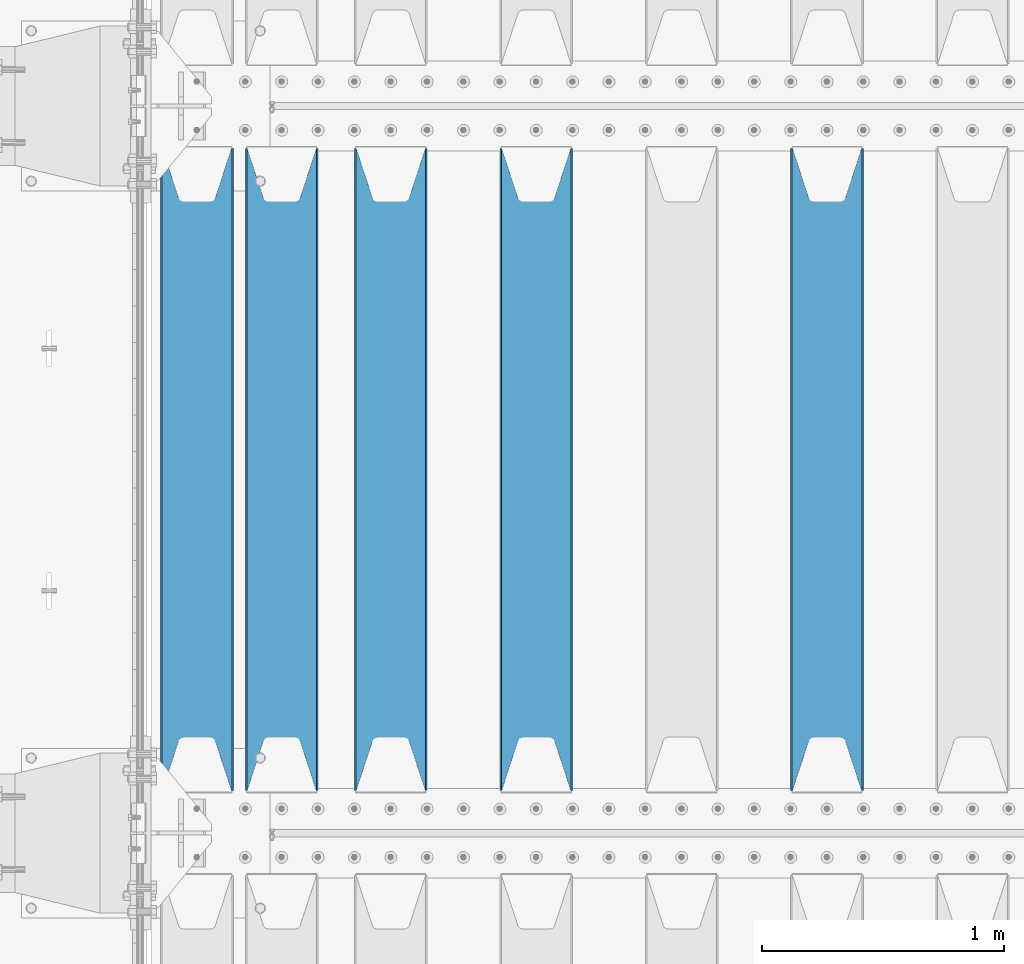
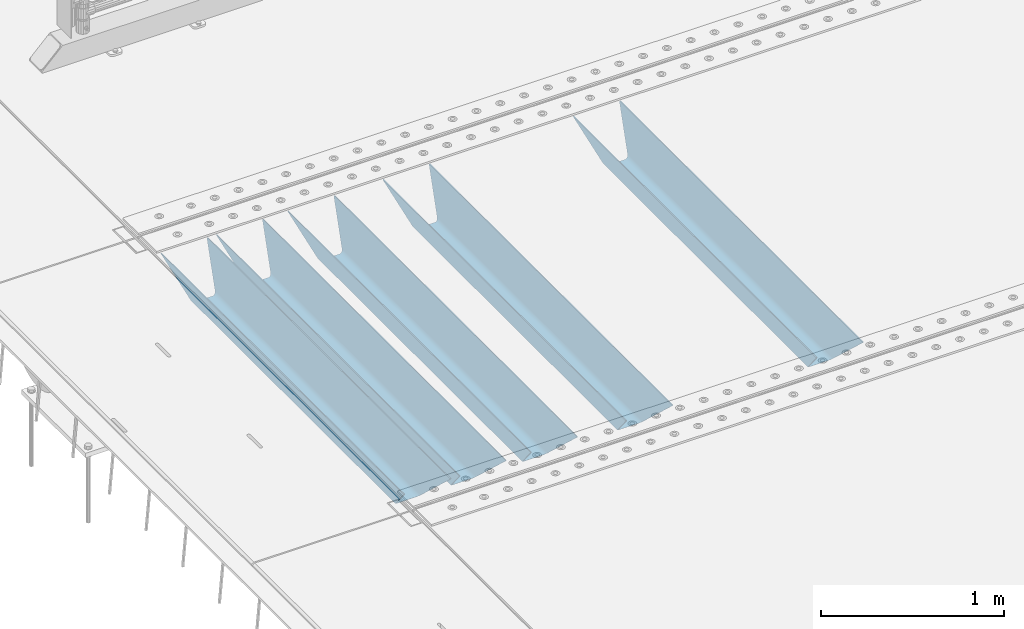
# One storey, part 110 of 247: 5 beams.
"""IFC2X3 building model written with IfcOpenShell, lengths in millimetres."""

import ifcopenshell
import ifcopenshell.guid

model = None  # the IFC model being written
_history = None  # IfcOwnerHistory: only IFC2X3 demands one
_inside = {}  # id of a spatial element -> (the spatial element, [elements in it])
_under = {}  # id of a project, library or spatial element -> (it, [spatial elements below it])
_declared = {}  # id of a project -> (the project, [libraries it declares])
_typed = {}  # id of a type object -> (the type object, [elements of that type])
_made_of = {}  # id of a material, layer set ... -> (it, [elements and type objects made of it])


def new_model(schema):
    """Start an empty IFC model of exactly this schema.

    Asked for "IFC4X3", IfcOpenShell would pick the latest addendum, in which some entities
    have other attributes; the version numbers below select the first issue.
    IFC2X3 requires an IfcOwnerHistory on every rooted entity: one is made here for all.
    """
    global model, _history
    if schema == "IFC4X3":
        model = ifcopenshell.file(schema_version=(4, 3, 0, 0))
    else:
        model = ifcopenshell.file(schema=schema)
    _inside.clear()
    _under.clear()
    _declared.clear()
    _typed.clear()
    _made_of.clear()
    _history = None
    if model.schema == "IFC2X3":
        org = make("IfcOrganization", Name="unknown")
        user = make(
            "IfcPersonAndOrganization",
            ThePerson=make("IfcPerson", FamilyName="unknown"),
            TheOrganization=org,
        )
        app = make(
            "IfcApplication",
            ApplicationDeveloper=org,
            Version="unknown",
            ApplicationFullName="unknown",
            ApplicationIdentifier="unknown",
        )
        _history = make(
            "IfcOwnerHistory",
            OwningUser=user,
            OwningApplication=app,
            ChangeAction="ADDED",
            CreationDate=0,
        )
    return model


def make(cls, **values):
    """One entity of the class cls with the attributes given. An attribute that is None is left unset."""
    return model.create_entity(
        cls, **{name: value for name, value in values.items() if value is not None}
    )


def rooted(cls, **values):
    """An entity with a GlobalId (a new one), such as an element, a storey or a relation."""
    return make(cls, GlobalId=ifcopenshell.guid.new(), OwnerHistory=_history, **values)


def si_unit(unit_type, name, prefix=None):
    """IfcSIUnit, for example si_unit("LENGTHUNIT", "METRE", prefix="MILLI")."""
    return make("IfcSIUnit", UnitType=unit_type, Prefix=prefix, Name=name)


def assignment(units):
    """IfcUnitAssignment: the units of a project."""
    return None if units is None else make("IfcUnitAssignment", Units=units)


def point(xyz):
    """IfcCartesianPoint."""
    return None if xyz is None else make("IfcCartesianPoint", Coordinates=xyz)


def direction(xyz):
    """IfcDirection."""
    return None if xyz is None else make("IfcDirection", DirectionRatios=xyz)


def frame(location, z_axis=None, x_axis=None):
    """IfcAxis2Placement3D, a coordinate frame: its origin and axes. An axis left out is left unset."""
    return make(
        "IfcAxis2Placement3D",
        Location=point(location),
        Axis=direction(z_axis),
        RefDirection=direction(x_axis),
    )


def origin_with_axes():
    """The frame at (0, 0, 0) with the z axis (0, 0, 1) and the x axis (1, 0, 0) written out."""
    return frame((0.0, 0.0, 0.0), z_axis=(0.0, 0.0, 1.0), x_axis=(1.0, 0.0, 0.0))


def place(relative_to, where):
    """IfcLocalPlacement: puts the frame where relative to a parent placement (None: the world)."""
    return make(
        "IfcLocalPlacement", PlacementRelTo=relative_to, RelativePlacement=where
    )


def context(
    kind, dimensions, precision=None, world=None, true_north=None, identifier=None
):
    """IfcGeometricRepresentationContext, for example the 3D "Model" context."""
    return make(
        "IfcGeometricRepresentationContext",
        ContextIdentifier=identifier,
        ContextType=kind,
        CoordinateSpaceDimension=dimensions,
        Precision=precision,
        WorldCoordinateSystem=world,
        TrueNorth=true_north,
    )


def subcontext(parent, identifier, kind, view, scale=None):
    """IfcGeometricRepresentationSubContext, for example "Body" below "Model"."""
    return make(
        "IfcGeometricRepresentationSubContext",
        ContextIdentifier=identifier,
        ContextType=kind,
        ParentContext=parent,
        TargetScale=scale,
        TargetView=view,
    )


def project(units=None, contexts=None):
    """IfcProject with its units and contexts."""
    return rooted(
        "IfcProject",
        Name="project",
        RepresentationContexts=contexts,
        UnitsInContext=assignment(units),
    )


def spatial(cls, under=None, at=None, **own):
    """A site, building, storey or space (cls), placed at a placement, below another one or the project."""
    s = rooted(cls, ObjectPlacement=at, **own)
    if under is not None:
        _under.setdefault(under.id(), (under, []))[1].append(s)
    return s


def faces_of(points, faces, orient=None, outer=None):
    """IfcFace entities. A face is a list of loops; a loop is a list of indices into points, from 0.

    orient and outer hold one flag for each loop. By default every Orientation is true, the
    first loop of a face is its IfcFaceOuterBound and the others are IfcFaceBound.
    """
    made = []
    for i, loops in enumerate(faces):
        bounds = []
        for j, loop in enumerate(loops):
            is_outer = j == 0 if outer is None else outer[i][j]
            bounds.append(
                make(
                    "IfcFaceOuterBound" if is_outer else "IfcFaceBound",
                    Bound=make("IfcPolyLoop", Polygon=[points[k] for k in loop]),
                    Orientation=True if orient is None else orient[i][j],
                )
            )
        made.append(make("IfcFace", Bounds=bounds))
    return made


def faceted_brep(points, faces, orient=None, outer=None, voids=None):
    """IfcFacetedBrep: a solid bounded by flat faces; with voids (closed shells), ...WithVoids."""
    shared = [point(p) for p in points]
    hull = make("IfcClosedShell", CfsFaces=faces_of(shared, faces, orient, outer))
    if voids is None:
        return make("IfcFacetedBrep", Outer=hull)
    return make(
        "IfcFacetedBrepWithVoids",
        Outer=hull,
        Voids=[
            make(cls, CfsFaces=faces_of(shared, fs, o, b)) for cls, fs, o, b in voids
        ],
    )


def shape(context_of_items, identifier, shape_type, items):
    """IfcShapeRepresentation: the items that make up one representation, for example the "Body"."""
    return make(
        "IfcShapeRepresentation",
        ContextOfItems=context_of_items,
        RepresentationIdentifier=identifier,
        RepresentationType=shape_type,
        Items=items,
    )


def material(Name=None, Category=None):
    """IfcMaterial."""
    return make("IfcMaterial", Name=Name, Category=Category)


def made_of(thing, what):
    """Note that an element or type object is made of a material, layer set ...; save() writes the relation."""
    if what is not None:
        _made_of.setdefault(what.id(), (what, []))[1].append(thing)
    return thing


def type_object(cls, material=None, **own):
    """A type object (cls), such as IfcWallType, which elements share."""
    return made_of(rooted(cls, **own), material)


def element(
    cls,
    number,
    at=None,
    inside=None,
    cuts=None,
    type_object=None,
    material=None,
    context=None,
    identifier="Body",
    shape_type=None,
    held_by="IfcProductDefinitionShape",
    body=None,
    shapes=None,
    **own,
):
    """One element of the class cls, such as IfcWall. Its Tag is "e" and its number.

    at: its placement. inside: the storey or other place that contains it. cuts: it is an
    opening in that element (IfcRelVoidsElement). A single representation is given by context,
    identifier, shape_type and body (its items); several are given by shapes. held_by: the class
    of the entity that holds the representations. save() writes the other relations.
    """
    e = rooted(cls, Tag="e%d" % number, ObjectPlacement=at, **own)
    if body is not None:
        shapes = [shape(context, identifier, shape_type, body)]
    if shapes is not None:
        e.Representation = make(held_by, Representations=shapes)
    if inside is not None:
        _inside.setdefault(inside.id(), (inside, []))[1].append(e)
    if cuts is not None:
        rooted(
            "IfcRelVoidsElement", RelatingBuildingElement=cuts, RelatedOpeningElement=e
        )
    if type_object is not None:
        _typed.setdefault(type_object.id(), (type_object, []))[1].append(e)
    return made_of(e, material)


def aggregate(whole, parts):
    """IfcRelAggregates: a whole, such as a stair, and the parts it consists of."""
    return rooted("IfcRelAggregates", RelatingObject=whole, RelatedObjects=parts)


def save(model, path):
    """Write the relations noted so far, then the file.

    IfcRelAggregates (storeys below a building ...), IfcRelContainedInSpatialStructure (elements
    in a storey), IfcRelDefinesByType, IfcRelAssociatesMaterial and IfcRelDeclares: one each for
    every whole, place, type object, material and project.
    """
    for whole, parts in _under.values():
        aggregate(whole, parts)
    for where, things in _inside.values():
        rooted(
            "IfcRelContainedInSpatialStructure",
            RelatedElements=things,
            RelatingStructure=where,
        )
    for kind, things in _typed.values():
        rooted("IfcRelDefinesByType", RelatedObjects=things, RelatingType=kind)
    for what, things in _made_of.values():
        rooted("IfcRelAssociatesMaterial", RelatedObjects=things, RelatingMaterial=what)
    for by, libraries in _declared.values():
        rooted("IfcRelDeclares", RelatingContext=by, RelatedDefinitions=libraries)
    model.write(path)


model = new_model("IFC2X3")

# Units and contexts
model_context = context("Model", 3, precision=1e-05, world=origin_with_axes())
body_context = subcontext(model_context, "Body", "Model", "MODEL_VIEW")
ifc_project = project(units=[si_unit("LENGTHUNIT", "METRE", prefix="MILLI"), si_unit("AREAUNIT", "SQUARE_METRE"), si_unit("VOLUMEUNIT", "CUBIC_METRE"), si_unit("MASSUNIT", "GRAM", prefix="KILO"), si_unit("TIMEUNIT", "SECOND"), si_unit("PLANEANGLEUNIT", "RADIAN"), si_unit("SOLIDANGLEUNIT", "STERADIAN"), si_unit("THERMODYNAMICTEMPERATUREUNIT", "DEGREE_CELSIUS"), si_unit("LUMINOUSINTENSITYUNIT", "LUMEN")], contexts=[model_context])

# Site, building, storey
site_placement = place(None, origin_with_axes())
site = spatial("IfcSite", under=ifc_project, at=site_placement, CompositionType="ELEMENT")
building_placement = place(site_placement, origin_with_axes())
building = spatial("IfcBuilding", under=site, at=building_placement, Name="Standard", CompositionType="ELEMENT")
storey_placement = place(building_placement, origin_with_axes())
storey = spatial("IfcBuildingStorey", under=building, at=storey_placement, Name="Undefined", CompositionType="ELEMENT", Elevation=0.0)

# Beams
ifc_material = material(Name="STEEL/S355N")
beam_type = type_object("IfcBeamType", PredefinedType="NOTDEFINED")
beam_1_placement = place(storey_placement, frame((2800.0, 3175.0, -115.0), z_axis=(0.0, 0.0, 1.0), x_axis=(0.0, 1.0, 0.0)))
element("IfcBeam", 1, at=beam_1_placement, inside=storey, type_object=beam_type, material=ifc_material, context=body_context, shape_type="Brep", body=[
    faceted_brep([(0.0, 150.0, 115.0), (0.0, 143.689999999999, 115.0), (2650.00000000297, 143.689999999999, 115.0), (2650.00000000297, 150.0, 115.0), (2650.00000000297, 142.059565218402, 110.0000000031), (2650.00000000297, 148.369565218403, 110.0000000031), (2441.90079219208, -80.1103600731112, -98.0992078077845), (2437.7588105432, -77.5672621345584, -102.241189456673), (2434.06523489746, -74.4080125315522, -105.934765102404), (2430.91086095089, -70.710272125576, -109.089139048974), (2428.37322971128, -66.5649389910068, -111.626770288588), (2426.51472138054, -62.0739139532889, -113.485278619323), (2425.38102192091, -57.3475956567672, -114.618978078955), (2424.99999999987, -52.5021667386536, -115.0), (2424.99999999987, 52.5021667386536, -115.0), (2425.38102192091, 57.3475956567672, -114.618978078955), (2426.51472138054, 62.0739139532889, -113.485278619323), (2428.37322971128, 66.5649389910068, -111.626770288588), (2430.91086095089, 70.710272125576, -109.089139048974), (2434.06523489746, 74.4080125315522, -105.934765102404), (2437.7588105432, 77.5672621345584, -102.241189456673), (2441.90079219208, 80.1103600731112, -98.0992078077846), (2446.38936140511, 81.9747917625791, -93.6106385947584), (2448.24948500409, 76.2713538057251, -91.7505149957729), (2444.62967112262, 74.76777986261, -95.3703288772456), (2441.28936334126, 72.7168944282894, -98.710636658607), (2438.31067330438, 70.1691124903846, -101.689326695487), (2435.76682334747, 67.1870637758839, -104.233176652398), (2433.72034654133, 63.8440531834895, -106.279653458539), (2432.22154950041, 60.222258798236, -107.778450499454), (2431.30727574265, 56.4107117849089, -108.692724257221), (2430.99999999987, 52.5031078186876, -109.0), (2430.99999999987, -52.5031078186876, -109.0), (2431.30727574265, -56.4107117849089, -108.692724257221), (2432.22154950041, -60.222258798236, -107.778450499454), (2433.72034654133, -63.8440531834895, -106.279653458539), (2435.76682334747, -67.1870637758839, -104.233176652398), (2438.31067330438, -70.1691124903846, -101.689326695487), (2441.28936334126, -72.7168944282894, -98.7106366586071), (2444.62967112262, -74.76777986261, -95.3703288772457), (2448.24948500409, -76.2713538057251, -91.7505149957729), (2650.00000000297, -142.059565218402, 110.0000000031), (2650.00000000297, -148.369565218403, 110.0000000031), (2446.38936140511, -81.9747917625791, -93.6106385947584), (2650.00000000297, -143.689999999999, 115.0), (2650.00000000297, -150.0, 115.0), (0.0, -143.689999999999, 115.0), (0.0, -150.0, 115.0), (0.0, -148.369565218261, 110.000000002663), (203.610638597422, -81.9747917625791, -93.6106385947584), (208.099207810448, -80.1103600731112, -98.0992078077845), (212.241189459336, -77.5672621345584, -102.241189456673), (215.934765105068, -74.4080125315522, -105.934765102404), (219.089139051637, -70.710272125576, -109.089139048974), (221.626770291251, -66.5649389910068, -111.626770288588), (223.485278621985, -62.0739139532889, -113.485278619323), (224.618978081617, -57.3475956567672, -114.618978078955), (225.000000002663, -52.5021667386536, -115.0), (225.000000002663, 52.5021667386536, -115.0), (224.618978081617, 57.3475956567672, -114.618978078955), (223.485278621985, 62.0739139532889, -113.485278619323), (221.626770291251, 66.5649389910068, -111.626770288588), (219.089139051637, 70.710272125576, -109.089139048974), (215.934765105068, 74.4080125315522, -105.934765102404), (212.241189459336, 77.5672621345584, -102.241189456673), (208.099207810448, 80.1103600731112, -98.0992078077846), (203.610638597422, 81.9747917625791, -93.6106385947584), (0.0, 148.369565218261, 110.000000002663), (0.0, 142.05956521826, 110.000000002663), (201.750514998436, 76.2713538057251, -91.7505149957729), (205.370328879908, 74.76777986261, -95.3703288772456), (208.710636661271, 72.7168944282894, -98.710636658607), (211.68932669815, 70.1691124903846, -101.689326695487), (214.233176655061, 67.1870637758839, -104.233176652398), (216.279653461202, 63.8440531834895, -106.279653458539), (217.778450502117, 60.222258798236, -107.778450499454), (218.692724259885, 56.4107117849089, -108.692724257221), (219.000000002663, 52.5031078186876, -109.0), (219.000000002663, -52.5031078186876, -109.0), (218.692724259885, -56.4107117849089, -108.692724257221), (217.778450502117, -60.222258798236, -107.778450499454), (216.279653461202, -63.8440531834895, -106.279653458539), (214.233176655061, -67.1870637758839, -104.233176652398), (211.68932669815, -70.1691124903846, -101.689326695487), (208.710636661271, -72.7168944282894, -98.7106366586071), (205.370328879908, -74.76777986261, -95.3703288772457), (201.750514998436, -76.2713538057251, -91.7505149957729), (0.0, -142.05956521826, 110.000000002663)], [[[0, 1, 2, 3]], [[3, 2, 4, 5]], [[6, 7, 8, 9, 10, 11, 12, 13, 14, 15, 16, 17, 18, 19, 20, 21, 22, 5, 4, 23, 24, 25, 26, 27, 28, 29, 30, 31, 32, 33, 34, 35, 36, 37, 38, 39, 40, 41, 42, 43]], [[44, 45, 42, 41]], [[46, 47, 45, 44]], [[43, 42, 45, 47, 48, 49]], [[6, 43, 49, 50]], [[7, 6, 50, 51]], [[8, 7, 51, 52]], [[9, 8, 52, 53]], [[10, 9, 53, 54]], [[11, 10, 54, 55]], [[12, 11, 55, 56]], [[13, 12, 56, 57]], [[14, 13, 57, 58]], [[15, 14, 58, 59]], [[16, 15, 59, 60]], [[17, 16, 60, 61]], [[18, 17, 61, 62]], [[19, 18, 62, 63]], [[20, 19, 63, 64]], [[21, 20, 64, 65]], [[22, 21, 65, 66]], [[0, 3, 5, 22, 66, 67]], [[1, 0, 67, 68]], [[23, 4, 2, 1, 68, 69]], [[24, 23, 69, 70]], [[25, 24, 70, 71]], [[26, 25, 71, 72]], [[27, 26, 72, 73]], [[28, 27, 73, 74]], [[29, 28, 74, 75]], [[30, 29, 75, 76]], [[31, 30, 76, 77]], [[32, 31, 77, 78]], [[33, 32, 78, 79]], [[34, 33, 79, 80]], [[35, 34, 80, 81]], [[36, 35, 81, 82]], [[37, 36, 82, 83]], [[38, 37, 83, 84]], [[39, 38, 84, 85]], [[40, 39, 85, 86]], [[46, 44, 41, 40, 86, 87]], [[47, 46, 87, 48]], [[86, 85, 84, 83, 82, 81, 80, 79, 78, 77, 76, 75, 74, 73, 72, 71, 70, 69, 68, 67, 66, 65, 64, 63, 62, 61, 60, 59, 58, 57, 56, 55, 54, 53, 52, 51, 50, 49, 48, 87]]]),
])
beam_2_placement = place(storey_placement, frame((1600.0, 3175.0, -115.0), z_axis=(0.0, 0.0, 1.0), x_axis=(0.0, 1.0, 0.0)))
element("IfcBeam", 2, at=beam_2_placement, inside=storey, type_object=beam_type, material=ifc_material, context=body_context, shape_type="Brep", body=[
    faceted_brep([(0.0, 150.0, 115.0), (0.0, 143.689999999999, 115.0), (2650.00000000297, 143.689999999999, 115.0), (2650.00000000297, 150.0, 115.0), (2650.00000000297, 142.059565218402, 110.0000000031), (2650.00000000297, 148.369565218403, 110.0000000031), (2441.90079219208, -80.1103600731112, -98.0992078077845), (2437.7588105432, -77.5672621345584, -102.241189456673), (2434.06523489746, -74.4080125315522, -105.934765102404), (2430.91086095089, -70.710272125576, -109.089139048974), (2428.37322971128, -66.5649389910068, -111.626770288588), (2426.51472138054, -62.0739139532889, -113.485278619323), (2425.38102192091, -57.3475956567672, -114.618978078955), (2424.99999999987, -52.5021667386536, -115.0), (2424.99999999987, 52.5021667386536, -115.0), (2425.38102192091, 57.3475956567672, -114.618978078955), (2426.51472138054, 62.0739139532889, -113.485278619323), (2428.37322971128, 66.5649389910068, -111.626770288588), (2430.91086095089, 70.710272125576, -109.089139048974), (2434.06523489746, 74.4080125315522, -105.934765102404), (2437.7588105432, 77.5672621345584, -102.241189456673), (2441.90079219208, 80.1103600731112, -98.0992078077846), (2446.38936140511, 81.9747917625791, -93.6106385947584), (2448.24948500409, 76.2713538057251, -91.7505149957729), (2444.62967112262, 74.76777986261, -95.3703288772456), (2441.28936334126, 72.7168944282894, -98.710636658607), (2438.31067330438, 70.1691124903846, -101.689326695487), (2435.76682334747, 67.1870637758839, -104.233176652398), (2433.72034654133, 63.8440531834895, -106.279653458539), (2432.22154950041, 60.222258798236, -107.778450499454), (2431.30727574265, 56.4107117849089, -108.692724257221), (2430.99999999987, 52.5031078186876, -109.0), (2430.99999999987, -52.5031078186876, -109.0), (2431.30727574265, -56.4107117849089, -108.692724257221), (2432.22154950041, -60.222258798236, -107.778450499454), (2433.72034654133, -63.8440531834895, -106.279653458539), (2435.76682334747, -67.1870637758839, -104.233176652398), (2438.31067330438, -70.1691124903846, -101.689326695487), (2441.28936334126, -72.7168944282894, -98.7106366586071), (2444.62967112262, -74.76777986261, -95.3703288772457), (2448.24948500409, -76.2713538057251, -91.7505149957729), (2650.00000000297, -142.059565218402, 110.0000000031), (2650.00000000297, -148.369565218403, 110.0000000031), (2446.38936140511, -81.9747917625791, -93.6106385947584), (2650.00000000297, -143.689999999999, 115.0), (2650.00000000297, -150.0, 115.0), (0.0, -143.689999999999, 115.0), (0.0, -150.0, 115.0), (0.0, -148.369565218261, 110.000000002663), (203.610638597422, -81.9747917625791, -93.6106385947584), (208.099207810448, -80.1103600731112, -98.0992078077845), (212.241189459336, -77.5672621345584, -102.241189456673), (215.934765105068, -74.4080125315522, -105.934765102404), (219.089139051637, -70.710272125576, -109.089139048974), (221.626770291251, -66.5649389910068, -111.626770288588), (223.485278621985, -62.0739139532889, -113.485278619323), (224.618978081617, -57.3475956567672, -114.618978078955), (225.000000002663, -52.5021667386536, -115.0), (225.000000002663, 52.5021667386536, -115.0), (224.618978081617, 57.3475956567672, -114.618978078955), (223.485278621985, 62.0739139532889, -113.485278619323), (221.626770291251, 66.5649389910068, -111.626770288588), (219.089139051637, 70.710272125576, -109.089139048974), (215.934765105068, 74.4080125315522, -105.934765102404), (212.241189459336, 77.5672621345584, -102.241189456673), (208.099207810448, 80.1103600731112, -98.0992078077846), (203.610638597422, 81.9747917625791, -93.6106385947584), (0.0, 148.369565218261, 110.000000002663), (0.0, 142.05956521826, 110.000000002663), (201.750514998436, 76.2713538057251, -91.7505149957729), (205.370328879908, 74.76777986261, -95.3703288772456), (208.710636661271, 72.7168944282894, -98.710636658607), (211.68932669815, 70.1691124903846, -101.689326695487), (214.233176655061, 67.1870637758839, -104.233176652398), (216.279653461202, 63.8440531834895, -106.279653458539), (217.778450502117, 60.222258798236, -107.778450499454), (218.692724259885, 56.4107117849089, -108.692724257221), (219.000000002663, 52.5031078186876, -109.0), (219.000000002663, -52.5031078186876, -109.0), (218.692724259885, -56.4107117849089, -108.692724257221), (217.778450502117, -60.222258798236, -107.778450499454), (216.279653461202, -63.8440531834895, -106.279653458539), (214.233176655061, -67.1870637758839, -104.233176652398), (211.68932669815, -70.1691124903846, -101.689326695487), (208.710636661271, -72.7168944282894, -98.7106366586071), (205.370328879908, -74.76777986261, -95.3703288772457), (201.750514998436, -76.2713538057251, -91.7505149957729), (0.0, -142.05956521826, 110.000000002663)], [[[0, 1, 2, 3]], [[3, 2, 4, 5]], [[6, 7, 8, 9, 10, 11, 12, 13, 14, 15, 16, 17, 18, 19, 20, 21, 22, 5, 4, 23, 24, 25, 26, 27, 28, 29, 30, 31, 32, 33, 34, 35, 36, 37, 38, 39, 40, 41, 42, 43]], [[44, 45, 42, 41]], [[46, 47, 45, 44]], [[43, 42, 45, 47, 48, 49]], [[6, 43, 49, 50]], [[7, 6, 50, 51]], [[8, 7, 51, 52]], [[9, 8, 52, 53]], [[10, 9, 53, 54]], [[11, 10, 54, 55]], [[12, 11, 55, 56]], [[13, 12, 56, 57]], [[14, 13, 57, 58]], [[15, 14, 58, 59]], [[16, 15, 59, 60]], [[17, 16, 60, 61]], [[18, 17, 61, 62]], [[19, 18, 62, 63]], [[20, 19, 63, 64]], [[21, 20, 64, 65]], [[22, 21, 65, 66]], [[0, 3, 5, 22, 66, 67]], [[1, 0, 67, 68]], [[23, 4, 2, 1, 68, 69]], [[24, 23, 69, 70]], [[25, 24, 70, 71]], [[26, 25, 71, 72]], [[27, 26, 72, 73]], [[28, 27, 73, 74]], [[29, 28, 74, 75]], [[30, 29, 75, 76]], [[31, 30, 76, 77]], [[32, 31, 77, 78]], [[33, 32, 78, 79]], [[34, 33, 79, 80]], [[35, 34, 80, 81]], [[36, 35, 81, 82]], [[37, 36, 82, 83]], [[38, 37, 83, 84]], [[39, 38, 84, 85]], [[40, 39, 85, 86]], [[46, 44, 41, 40, 86, 87]], [[47, 46, 87, 48]], [[86, 85, 84, 83, 82, 81, 80, 79, 78, 77, 76, 75, 74, 73, 72, 71, 70, 69, 68, 67, 66, 65, 64, 63, 62, 61, 60, 59, 58, 57, 56, 55, 54, 53, 52, 51, 50, 49, 48, 87]]]),
])
beam_3_placement = place(storey_placement, frame((1000.0, 3175.0, -115.0), z_axis=(0.0, 0.0, 1.0), x_axis=(0.0, 1.0, 0.0)))
element("IfcBeam", 3, at=beam_3_placement, inside=storey, type_object=beam_type, material=ifc_material, context=body_context, shape_type="Brep", body=[
    faceted_brep([(0.0, 150.0, 115.0), (0.0, 143.689999999999, 115.0), (2650.00000000297, 143.689999999999, 115.0), (2650.00000000297, 150.0, 115.0), (2650.00000000297, 142.059565218402, 110.0000000031), (2650.00000000297, 148.369565218403, 110.0000000031), (2441.90079219208, -80.1103600731112, -98.0992078077845), (2437.7588105432, -77.5672621345584, -102.241189456673), (2434.06523489746, -74.4080125315522, -105.934765102404), (2430.91086095089, -70.710272125576, -109.089139048974), (2428.37322971128, -66.5649389910068, -111.626770288588), (2426.51472138054, -62.0739139532889, -113.485278619323), (2425.38102192091, -57.3475956567672, -114.618978078955), (2424.99999999987, -52.5021667386536, -115.0), (2424.99999999987, 52.5021667386536, -115.0), (2425.38102192091, 57.3475956567672, -114.618978078955), (2426.51472138054, 62.0739139532889, -113.485278619323), (2428.37322971128, 66.5649389910068, -111.626770288588), (2430.91086095089, 70.710272125576, -109.089139048974), (2434.06523489746, 74.4080125315522, -105.934765102404), (2437.7588105432, 77.5672621345584, -102.241189456673), (2441.90079219208, 80.1103600731112, -98.0992078077846), (2446.38936140511, 81.9747917625791, -93.6106385947584), (2448.24948500409, 76.2713538057251, -91.7505149957729), (2444.62967112262, 74.76777986261, -95.3703288772456), (2441.28936334126, 72.7168944282894, -98.710636658607), (2438.31067330438, 70.1691124903846, -101.689326695487), (2435.76682334747, 67.1870637758839, -104.233176652398), (2433.72034654133, 63.8440531834895, -106.279653458539), (2432.22154950041, 60.222258798236, -107.778450499454), (2431.30727574265, 56.4107117849089, -108.692724257221), (2430.99999999987, 52.5031078186876, -109.0), (2430.99999999987, -52.5031078186876, -109.0), (2431.30727574265, -56.4107117849089, -108.692724257221), (2432.22154950041, -60.222258798236, -107.778450499454), (2433.72034654133, -63.8440531834895, -106.279653458539), (2435.76682334747, -67.1870637758839, -104.233176652398), (2438.31067330438, -70.1691124903846, -101.689326695487), (2441.28936334126, -72.7168944282894, -98.7106366586071), (2444.62967112262, -74.76777986261, -95.3703288772457), (2448.24948500409, -76.2713538057251, -91.7505149957729), (2650.00000000297, -142.059565218402, 110.0000000031), (2650.00000000297, -148.369565218403, 110.0000000031), (2446.38936140511, -81.9747917625791, -93.6106385947584), (2650.00000000297, -143.689999999999, 115.0), (2650.00000000297, -150.0, 115.0), (0.0, -143.689999999999, 115.0), (0.0, -150.0, 115.0), (0.0, -148.369565218261, 110.000000002663), (203.610638597422, -81.9747917625791, -93.6106385947584), (208.099207810448, -80.1103600731112, -98.0992078077845), (212.241189459336, -77.5672621345584, -102.241189456673), (215.934765105068, -74.4080125315522, -105.934765102404), (219.089139051637, -70.710272125576, -109.089139048974), (221.626770291251, -66.5649389910068, -111.626770288588), (223.485278621985, -62.0739139532889, -113.485278619323), (224.618978081617, -57.3475956567672, -114.618978078955), (225.000000002663, -52.5021667386536, -115.0), (225.000000002663, 52.5021667386536, -115.0), (224.618978081617, 57.3475956567672, -114.618978078955), (223.485278621985, 62.0739139532889, -113.485278619323), (221.626770291251, 66.5649389910068, -111.626770288588), (219.089139051637, 70.710272125576, -109.089139048974), (215.934765105068, 74.4080125315522, -105.934765102404), (212.241189459336, 77.5672621345584, -102.241189456673), (208.099207810448, 80.1103600731112, -98.0992078077846), (203.610638597422, 81.9747917625791, -93.6106385947584), (0.0, 148.369565218261, 110.000000002663), (0.0, 142.05956521826, 110.000000002663), (201.750514998436, 76.2713538057251, -91.7505149957729), (205.370328879908, 74.76777986261, -95.3703288772456), (208.710636661271, 72.7168944282894, -98.710636658607), (211.68932669815, 70.1691124903846, -101.689326695487), (214.233176655061, 67.1870637758839, -104.233176652398), (216.279653461202, 63.8440531834895, -106.279653458539), (217.778450502117, 60.222258798236, -107.778450499454), (218.692724259885, 56.4107117849089, -108.692724257221), (219.000000002663, 52.5031078186876, -109.0), (219.000000002663, -52.5031078186876, -109.0), (218.692724259885, -56.4107117849089, -108.692724257221), (217.778450502117, -60.222258798236, -107.778450499454), (216.279653461202, -63.8440531834895, -106.279653458539), (214.233176655061, -67.1870637758839, -104.233176652398), (211.68932669815, -70.1691124903846, -101.689326695487), (208.710636661271, -72.7168944282894, -98.7106366586071), (205.370328879908, -74.76777986261, -95.3703288772457), (201.750514998436, -76.2713538057251, -91.7505149957729), (0.0, -142.05956521826, 110.000000002663)], [[[0, 1, 2, 3]], [[3, 2, 4, 5]], [[6, 7, 8, 9, 10, 11, 12, 13, 14, 15, 16, 17, 18, 19, 20, 21, 22, 5, 4, 23, 24, 25, 26, 27, 28, 29, 30, 31, 32, 33, 34, 35, 36, 37, 38, 39, 40, 41, 42, 43]], [[44, 45, 42, 41]], [[46, 47, 45, 44]], [[43, 42, 45, 47, 48, 49]], [[6, 43, 49, 50]], [[7, 6, 50, 51]], [[8, 7, 51, 52]], [[9, 8, 52, 53]], [[10, 9, 53, 54]], [[11, 10, 54, 55]], [[12, 11, 55, 56]], [[13, 12, 56, 57]], [[14, 13, 57, 58]], [[15, 14, 58, 59]], [[16, 15, 59, 60]], [[17, 16, 60, 61]], [[18, 17, 61, 62]], [[19, 18, 62, 63]], [[20, 19, 63, 64]], [[21, 20, 64, 65]], [[22, 21, 65, 66]], [[0, 3, 5, 22, 66, 67]], [[1, 0, 67, 68]], [[23, 4, 2, 1, 68, 69]], [[24, 23, 69, 70]], [[25, 24, 70, 71]], [[26, 25, 71, 72]], [[27, 26, 72, 73]], [[28, 27, 73, 74]], [[29, 28, 74, 75]], [[30, 29, 75, 76]], [[31, 30, 76, 77]], [[32, 31, 77, 78]], [[33, 32, 78, 79]], [[34, 33, 79, 80]], [[35, 34, 80, 81]], [[36, 35, 81, 82]], [[37, 36, 82, 83]], [[38, 37, 83, 84]], [[39, 38, 84, 85]], [[40, 39, 85, 86]], [[46, 44, 41, 40, 86, 87]], [[47, 46, 87, 48]], [[86, 85, 84, 83, 82, 81, 80, 79, 78, 77, 76, 75, 74, 73, 72, 71, 70, 69, 68, 67, 66, 65, 64, 63, 62, 61, 60, 59, 58, 57, 56, 55, 54, 53, 52, 51, 50, 49, 48, 87]]]),
])
beam_4_placement = place(storey_placement, frame((550.0, 3175.0, -115.0), z_axis=(0.0, 0.0, 1.0), x_axis=(0.0, 1.0, 0.0)))
element("IfcBeam", 4, at=beam_4_placement, inside=storey, type_object=beam_type, material=ifc_material, context=body_context, shape_type="Brep", body=[
    faceted_brep([(0.0, 150.0, 115.0), (0.0, 143.689999999999, 115.0), (2650.00000000297, 143.689999999999, 115.0), (2650.00000000297, 150.0, 115.0), (2650.00000000297, 142.059565218402, 110.0000000031), (2650.00000000297, 148.369565218403, 110.0000000031), (2441.90079219208, -80.1103600731112, -98.0992078077845), (2437.7588105432, -77.5672621345584, -102.241189456673), (2434.06523489746, -74.4080125315522, -105.934765102404), (2430.91086095089, -70.710272125576, -109.089139048974), (2428.37322971128, -66.5649389910068, -111.626770288588), (2426.51472138054, -62.0739139532889, -113.485278619323), (2425.38102192091, -57.3475956567672, -114.618978078955), (2424.99999999987, -52.5021667386536, -115.0), (2424.99999999987, 52.5021667386536, -115.0), (2425.38102192091, 57.3475956567672, -114.618978078955), (2426.51472138054, 62.0739139532889, -113.485278619323), (2428.37322971128, 66.5649389910068, -111.626770288588), (2430.91086095089, 70.710272125576, -109.089139048974), (2434.06523489746, 74.4080125315522, -105.934765102404), (2437.7588105432, 77.5672621345584, -102.241189456673), (2441.90079219208, 80.1103600731112, -98.0992078077846), (2446.38936140511, 81.9747917625791, -93.6106385947584), (2448.24948500409, 76.2713538057251, -91.7505149957729), (2444.62967112262, 74.76777986261, -95.3703288772456), (2441.28936334126, 72.7168944282894, -98.710636658607), (2438.31067330438, 70.1691124903846, -101.689326695487), (2435.76682334747, 67.1870637758839, -104.233176652398), (2433.72034654133, 63.8440531834895, -106.279653458539), (2432.22154950041, 60.222258798236, -107.778450499454), (2431.30727574265, 56.4107117849089, -108.692724257221), (2430.99999999987, 52.5031078186876, -109.0), (2430.99999999987, -52.5031078186876, -109.0), (2431.30727574265, -56.4107117849089, -108.692724257221), (2432.22154950041, -60.222258798236, -107.778450499454), (2433.72034654133, -63.8440531834895, -106.279653458539), (2435.76682334747, -67.1870637758839, -104.233176652398), (2438.31067330438, -70.1691124903846, -101.689326695487), (2441.28936334126, -72.7168944282894, -98.7106366586071), (2444.62967112262, -74.76777986261, -95.3703288772457), (2448.24948500409, -76.2713538057251, -91.7505149957729), (2650.00000000297, -142.059565218402, 110.0000000031), (2650.00000000297, -148.369565218403, 110.0000000031), (2446.38936140511, -81.9747917625791, -93.6106385947584), (2650.00000000297, -143.689999999999, 115.0), (2650.00000000297, -150.0, 115.0), (0.0, -143.689999999999, 115.0), (0.0, -150.0, 115.0), (0.0, -148.369565218261, 110.000000002663), (203.610638597422, -81.9747917625791, -93.6106385947584), (208.099207810448, -80.1103600731112, -98.0992078077845), (212.241189459336, -77.5672621345584, -102.241189456673), (215.934765105068, -74.4080125315522, -105.934765102404), (219.089139051637, -70.710272125576, -109.089139048974), (221.626770291251, -66.5649389910068, -111.626770288588), (223.485278621985, -62.0739139532889, -113.485278619323), (224.618978081617, -57.3475956567672, -114.618978078955), (225.000000002663, -52.5021667386536, -115.0), (225.000000002663, 52.5021667386536, -115.0), (224.618978081617, 57.3475956567672, -114.618978078955), (223.485278621985, 62.0739139532889, -113.485278619323), (221.626770291251, 66.5649389910068, -111.626770288588), (219.089139051637, 70.710272125576, -109.089139048974), (215.934765105068, 74.4080125315522, -105.934765102404), (212.241189459336, 77.5672621345584, -102.241189456673), (208.099207810448, 80.1103600731112, -98.0992078077846), (203.610638597422, 81.9747917625791, -93.6106385947584), (0.0, 148.369565218261, 110.000000002663), (0.0, 142.05956521826, 110.000000002663), (201.750514998436, 76.2713538057251, -91.7505149957729), (205.370328879908, 74.76777986261, -95.3703288772456), (208.710636661271, 72.7168944282894, -98.710636658607), (211.68932669815, 70.1691124903846, -101.689326695487), (214.233176655061, 67.1870637758839, -104.233176652398), (216.279653461202, 63.8440531834895, -106.279653458539), (217.778450502117, 60.222258798236, -107.778450499454), (218.692724259885, 56.4107117849089, -108.692724257221), (219.000000002663, 52.5031078186876, -109.0), (219.000000002663, -52.5031078186876, -109.0), (218.692724259885, -56.4107117849089, -108.692724257221), (217.778450502117, -60.222258798236, -107.778450499454), (216.279653461202, -63.8440531834895, -106.279653458539), (214.233176655061, -67.1870637758839, -104.233176652398), (211.68932669815, -70.1691124903846, -101.689326695487), (208.710636661271, -72.7168944282894, -98.7106366586071), (205.370328879908, -74.76777986261, -95.3703288772457), (201.750514998436, -76.2713538057251, -91.7505149957729), (0.0, -142.05956521826, 110.000000002663)], [[[0, 1, 2, 3]], [[3, 2, 4, 5]], [[6, 7, 8, 9, 10, 11, 12, 13, 14, 15, 16, 17, 18, 19, 20, 21, 22, 5, 4, 23, 24, 25, 26, 27, 28, 29, 30, 31, 32, 33, 34, 35, 36, 37, 38, 39, 40, 41, 42, 43]], [[44, 45, 42, 41]], [[46, 47, 45, 44]], [[43, 42, 45, 47, 48, 49]], [[6, 43, 49, 50]], [[7, 6, 50, 51]], [[8, 7, 51, 52]], [[9, 8, 52, 53]], [[10, 9, 53, 54]], [[11, 10, 54, 55]], [[12, 11, 55, 56]], [[13, 12, 56, 57]], [[14, 13, 57, 58]], [[15, 14, 58, 59]], [[16, 15, 59, 60]], [[17, 16, 60, 61]], [[18, 17, 61, 62]], [[19, 18, 62, 63]], [[20, 19, 63, 64]], [[21, 20, 64, 65]], [[22, 21, 65, 66]], [[0, 3, 5, 22, 66, 67]], [[1, 0, 67, 68]], [[23, 4, 2, 1, 68, 69]], [[24, 23, 69, 70]], [[25, 24, 70, 71]], [[26, 25, 71, 72]], [[27, 26, 72, 73]], [[28, 27, 73, 74]], [[29, 28, 74, 75]], [[30, 29, 75, 76]], [[31, 30, 76, 77]], [[32, 31, 77, 78]], [[33, 32, 78, 79]], [[34, 33, 79, 80]], [[35, 34, 80, 81]], [[36, 35, 81, 82]], [[37, 36, 82, 83]], [[38, 37, 83, 84]], [[39, 38, 84, 85]], [[40, 39, 85, 86]], [[46, 44, 41, 40, 86, 87]], [[47, 46, 87, 48]], [[86, 85, 84, 83, 82, 81, 80, 79, 78, 77, 76, 75, 74, 73, 72, 71, 70, 69, 68, 67, 66, 65, 64, 63, 62, 61, 60, 59, 58, 57, 56, 55, 54, 53, 52, 51, 50, 49, 48, 87]]]),
])
beam_5_placement = place(storey_placement, frame((200.0, 3175.0, -115.0), z_axis=(0.0, 0.0, 1.0), x_axis=(0.0, 1.0, 0.0)))
element("IfcBeam", 5, at=beam_5_placement, inside=storey, type_object=beam_type, material=ifc_material, context=body_context, shape_type="Brep", body=[
    faceted_brep([(0.0, 150.0, 115.0), (0.0, 143.689999999999, 115.0), (2650.00000000297, 143.689999999999, 115.0), (2650.00000000297, 150.0, 115.0), (2650.00000000297, 142.059565218402, 110.0000000031), (2650.00000000297, 148.369565218403, 110.0000000031), (2441.90079219208, -80.1103600731112, -98.0992078077845), (2437.7588105432, -77.5672621345584, -102.241189456673), (2434.06523489746, -74.4080125315522, -105.934765102404), (2430.91086095089, -70.710272125576, -109.089139048974), (2428.37322971128, -66.5649389910068, -111.626770288588), (2426.51472138054, -62.0739139532889, -113.485278619323), (2425.38102192091, -57.3475956567672, -114.618978078955), (2424.99999999987, -52.5021667386536, -115.0), (2424.99999999987, 52.5021667386536, -115.0), (2425.38102192091, 57.3475956567672, -114.618978078955), (2426.51472138054, 62.0739139532889, -113.485278619323), (2428.37322971128, 66.5649389910068, -111.626770288588), (2430.91086095089, 70.710272125576, -109.089139048974), (2434.06523489746, 74.4080125315522, -105.934765102404), (2437.7588105432, 77.5672621345584, -102.241189456673), (2441.90079219208, 80.1103600731112, -98.0992078077846), (2446.38936140511, 81.9747917625791, -93.6106385947584), (2448.24948500409, 76.2713538057251, -91.7505149957729), (2444.62967112262, 74.76777986261, -95.3703288772456), (2441.28936334126, 72.7168944282894, -98.710636658607), (2438.31067330438, 70.1691124903846, -101.689326695487), (2435.76682334747, 67.1870637758839, -104.233176652398), (2433.72034654133, 63.8440531834895, -106.279653458539), (2432.22154950041, 60.222258798236, -107.778450499454), (2431.30727574265, 56.4107117849089, -108.692724257221), (2430.99999999987, 52.5031078186876, -109.0), (2430.99999999987, -52.5031078186876, -109.0), (2431.30727574265, -56.4107117849089, -108.692724257221), (2432.22154950041, -60.222258798236, -107.778450499454), (2433.72034654133, -63.8440531834895, -106.279653458539), (2435.76682334747, -67.1870637758839, -104.233176652398), (2438.31067330438, -70.1691124903846, -101.689326695487), (2441.28936334126, -72.7168944282894, -98.7106366586071), (2444.62967112262, -74.76777986261, -95.3703288772457), (2448.24948500409, -76.2713538057251, -91.7505149957729), (2650.00000000297, -142.059565218402, 110.0000000031), (2650.00000000297, -148.369565218403, 110.0000000031), (2446.38936140511, -81.9747917625791, -93.6106385947584), (2650.00000000297, -143.689999999999, 115.0), (2650.00000000297, -150.0, 115.0), (0.0, -143.689999999999, 115.0), (0.0, -150.0, 115.0), (0.0, -148.369565218261, 110.000000002663), (203.610638597422, -81.9747917625791, -93.6106385947584), (208.099207810448, -80.1103600731112, -98.0992078077845), (212.241189459336, -77.5672621345584, -102.241189456673), (215.934765105068, -74.4080125315522, -105.934765102404), (219.089139051637, -70.710272125576, -109.089139048974), (221.626770291251, -66.5649389910068, -111.626770288588), (223.485278621985, -62.0739139532889, -113.485278619323), (224.618978081617, -57.3475956567672, -114.618978078955), (225.000000002663, -52.5021667386536, -115.0), (225.000000002663, 52.5021667386536, -115.0), (224.618978081617, 57.3475956567672, -114.618978078955), (223.485278621985, 62.0739139532889, -113.485278619323), (221.626770291251, 66.5649389910068, -111.626770288588), (219.089139051637, 70.710272125576, -109.089139048974), (215.934765105068, 74.4080125315522, -105.934765102404), (212.241189459336, 77.5672621345584, -102.241189456673), (208.099207810448, 80.1103600731112, -98.0992078077846), (203.610638597422, 81.9747917625791, -93.6106385947584), (0.0, 148.369565218261, 110.000000002663), (0.0, 142.05956521826, 110.000000002663), (201.750514998436, 76.2713538057251, -91.7505149957729), (205.370328879908, 74.76777986261, -95.3703288772456), (208.710636661271, 72.7168944282894, -98.710636658607), (211.68932669815, 70.1691124903846, -101.689326695487), (214.233176655061, 67.1870637758839, -104.233176652398), (216.279653461202, 63.8440531834895, -106.279653458539), (217.778450502117, 60.222258798236, -107.778450499454), (218.692724259885, 56.4107117849089, -108.692724257221), (219.000000002663, 52.5031078186876, -109.0), (219.000000002663, -52.5031078186876, -109.0), (218.692724259885, -56.4107117849089, -108.692724257221), (217.778450502117, -60.222258798236, -107.778450499454), (216.279653461202, -63.8440531834895, -106.279653458539), (214.233176655061, -67.1870637758839, -104.233176652398), (211.68932669815, -70.1691124903846, -101.689326695487), (208.710636661271, -72.7168944282894, -98.7106366586071), (205.370328879908, -74.76777986261, -95.3703288772457), (201.750514998436, -76.2713538057251, -91.7505149957729), (0.0, -142.05956521826, 110.000000002663)], [[[0, 1, 2, 3]], [[3, 2, 4, 5]], [[6, 7, 8, 9, 10, 11, 12, 13, 14, 15, 16, 17, 18, 19, 20, 21, 22, 5, 4, 23, 24, 25, 26, 27, 28, 29, 30, 31, 32, 33, 34, 35, 36, 37, 38, 39, 40, 41, 42, 43]], [[44, 45, 42, 41]], [[46, 47, 45, 44]], [[43, 42, 45, 47, 48, 49]], [[6, 43, 49, 50]], [[7, 6, 50, 51]], [[8, 7, 51, 52]], [[9, 8, 52, 53]], [[10, 9, 53, 54]], [[11, 10, 54, 55]], [[12, 11, 55, 56]], [[13, 12, 56, 57]], [[14, 13, 57, 58]], [[15, 14, 58, 59]], [[16, 15, 59, 60]], [[17, 16, 60, 61]], [[18, 17, 61, 62]], [[19, 18, 62, 63]], [[20, 19, 63, 64]], [[21, 20, 64, 65]], [[22, 21, 65, 66]], [[0, 3, 5, 22, 66, 67]], [[1, 0, 67, 68]], [[23, 4, 2, 1, 68, 69]], [[24, 23, 69, 70]], [[25, 24, 70, 71]], [[26, 25, 71, 72]], [[27, 26, 72, 73]], [[28, 27, 73, 74]], [[29, 28, 74, 75]], [[30, 29, 75, 76]], [[31, 30, 76, 77]], [[32, 31, 77, 78]], [[33, 32, 78, 79]], [[34, 33, 79, 80]], [[35, 34, 80, 81]], [[36, 35, 81, 82]], [[37, 36, 82, 83]], [[38, 37, 83, 84]], [[39, 38, 84, 85]], [[40, 39, 85, 86]], [[46, 44, 41, 40, 86, 87]], [[47, 46, 87, 48]], [[86, 85, 84, 83, 82, 81, 80, 79, 78, 77, 76, 75, 74, 73, 72, 71, 70, 69, 68, 67, 66, 65, 64, 63, 62, 61, 60, 59, 58, 57, 56, 55, 54, 53, 52, 51, 50, 49, 48, 87]]]),
])

save(model, "model.ifc")
